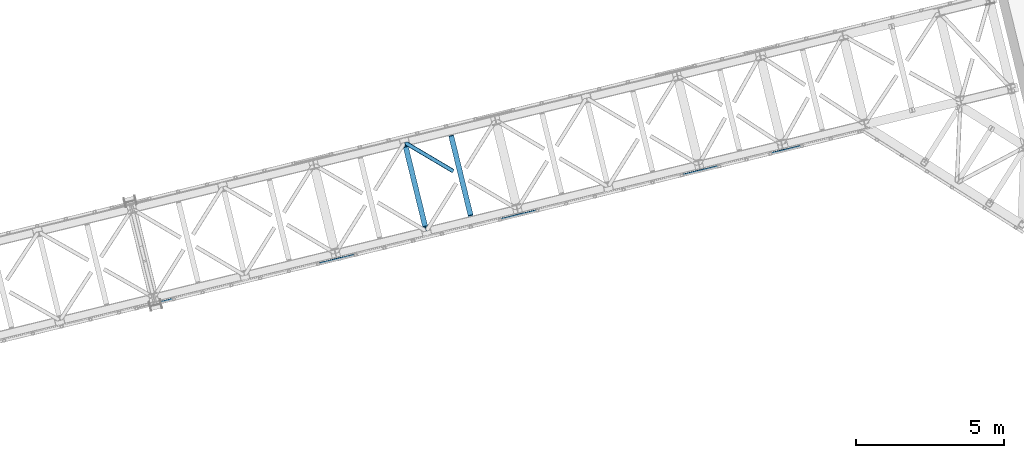
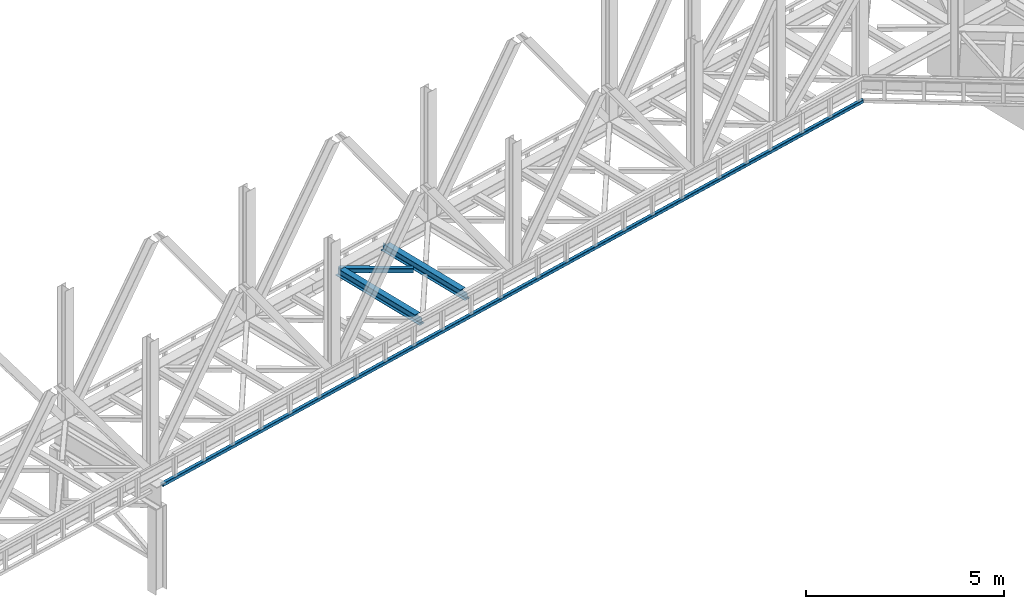
# One storey, part 66 of 92: 3 beams, 1 member.
"""IFC4 building model written with IfcOpenShell, lengths in millimetres."""

from ifc_helpers import new_model, entity, si_unit, converted_unit, derived_unit, direction, frame, origin, place, context, subcontext, project, spatial, triangles, polygons, material, type_object, element, save


model = new_model("IFC4")

# Units and contexts
model_context = context("Model", 3, precision=0.01, world=origin(), true_north=direction((6.12303176911189e-17, 1.0)))
plan_context = context("Plan", 3, precision=0.01, world=origin(), true_north=direction((6.12303176911189e-17, 1.0)))
body_context = subcontext(model_context, "Body", "Model", "MODEL_VIEW")
ifc_project = project(units=[si_unit("LENGTHUNIT", "METRE", prefix="MILLI"), si_unit("AREAUNIT", "SQUARE_METRE"), si_unit("VOLUMEUNIT", "CUBIC_METRE"), converted_unit("PLANEANGLEUNIT", "DEGREE", entity("IfcRatioMeasure", 0.0174532925199433), si_unit("PLANEANGLEUNIT", "RADIAN"), dimensions=[0, 0, 0, 0, 0, 0, 0]), si_unit("MASSUNIT", "GRAM", prefix="KILO"), derived_unit("MASSDENSITYUNIT", [(si_unit("MASSUNIT", "GRAM", prefix="KILO"), 1), (si_unit("LENGTHUNIT", "METRE"), -3)]), derived_unit("MOMENTOFINERTIAUNIT", [(si_unit("LENGTHUNIT", "METRE"), 4)]), si_unit("TIMEUNIT", "SECOND"), si_unit("FREQUENCYUNIT", "HERTZ"), si_unit("THERMODYNAMICTEMPERATUREUNIT", "DEGREE_CELSIUS"), derived_unit("THERMALTRANSMITTANCEUNIT", [(si_unit("MASSUNIT", "GRAM", prefix="KILO"), 1), (si_unit("THERMODYNAMICTEMPERATUREUNIT", "KELVIN"), -1), (si_unit("TIMEUNIT", "SECOND"), -3)]), derived_unit("VOLUMETRICFLOWRATEUNIT", [(si_unit("LENGTHUNIT", "METRE"), 3), (si_unit("TIMEUNIT", "SECOND"), -1)]), derived_unit("MASSFLOWRATEUNIT", [(si_unit("MASSUNIT", "GRAM", prefix="KILO"), 1), (si_unit("TIMEUNIT", "SECOND"), -1)]), derived_unit("ROTATIONALFREQUENCYUNIT", [(si_unit("TIMEUNIT", "SECOND"), -1)]), si_unit("ELECTRICCURRENTUNIT", "AMPERE"), si_unit("ELECTRICVOLTAGEUNIT", "VOLT"), si_unit("POWERUNIT", "WATT"), si_unit("FORCEUNIT", "NEWTON", prefix="KILO"), si_unit("ILLUMINANCEUNIT", "LUX"), si_unit("LUMINOUSFLUXUNIT", "LUMEN"), si_unit("LUMINOUSINTENSITYUNIT", "CANDELA"), derived_unit("USERDEFINED", [(si_unit("MASSUNIT", "GRAM", prefix="KILO"), -1), (si_unit("LENGTHUNIT", "METRE"), -2), (si_unit("TIMEUNIT", "SECOND"), 3), (si_unit("LUMINOUSFLUXUNIT", "LUMEN"), 1)]), derived_unit("LINEARVELOCITYUNIT", [(si_unit("LENGTHUNIT", "METRE"), 1), (si_unit("TIMEUNIT", "SECOND"), -1)]), si_unit("PRESSUREUNIT", "PASCAL"), derived_unit("USERDEFINED", [(si_unit("LENGTHUNIT", "METRE"), -2), (si_unit("MASSUNIT", "GRAM", prefix="KILO"), 1), (si_unit("TIMEUNIT", "SECOND"), -2)]), derived_unit("LINEARFORCEUNIT", [(si_unit("MASSUNIT", "GRAM", prefix="KILO"), 1), (si_unit("LENGTHUNIT", "METRE"), 1), (si_unit("TIMEUNIT", "SECOND"), -2), (si_unit("LENGTHUNIT", "METRE"), -1)]), derived_unit("PLANARFORCEUNIT", [(si_unit("MASSUNIT", "GRAM", prefix="KILO"), 1), (si_unit("LENGTHUNIT", "METRE"), 1), (si_unit("TIMEUNIT", "SECOND"), -2), (si_unit("LENGTHUNIT", "METRE"), -2)])], contexts=[model_context, plan_context])

# Site, building, storey
site_placement = place(None, origin())
site = spatial("IfcSite", under=ifc_project, at=site_placement, CompositionType="ELEMENT")
building_placement = place(site_placement, origin())
building = spatial("IfcBuilding", under=site, at=building_placement, CompositionType="ELEMENT")
storey_placement = place(building_placement, frame((0.0, 0.0, 15900.0)))
storey = spatial("IfcBuildingStorey", under=building, at=storey_placement, Name="05", CompositionType="ELEMENT", Elevation=15900.0)

# Beams
ifc_material = material(Name="Metal painted (White)")
beam_type_1 = type_object("IfcBeamType", PredefinedType="BEAM")
beam_1_placement = place(storey_placement, frame((-21033.99, 12667.67, 3441.0)))
element("IfcBeam", 1, at=beam_1_placement, inside=storey, type_object=beam_type_1, material=ifc_material, ObjectType="Steel Beam", PredefinedType="BEAM", context=body_context, shape_type="Tessellation", body=[
    polygons([(896.722476515612, 41.4445662733146, 11.000000000004), (896.722476515612, 41.4445662733146, 2.16573425859679e-12), (170.021610174765, 3022.65205668043, 2.16573425859679e-12), (170.021610174765, 3022.65205668043, 11.000000000004), (830.65693656199, 25.3403919499699, 11.000000000004), (103.956070221139, 3006.54788235708, 11.000000000004), (824.708186540694, 23.8903211957439, 12.2179274798217), (98.007320199847, 3005.09781160286, 12.2179274798217), (819.665079784585, 22.6610105689237, 15.6862915010257), (92.964213443734, 3003.86850097604, 15.6862915010257), (816.295383581409, 21.8396114687162, 20.8770650821657), (89.5945172405581, 3003.04710187583, 20.8770650821657), (815.112103631732, 21.5511744621271, 27.0000000000047), (88.4112372908809, 3002.75866486924, 27.0000000000047), (81.6103728838844, 3001.1008822183, 27.0000000000047), (81.6103728838888, 3001.1008822183, 203.000000000006), (88.4112372908939, 3002.75866486924, 203.000000000006), (0.0, 2981.20749040711, 2.16573425859679e-12), (4.33146851719357e-12, 2981.20749040712, 10.9999999999997), (66.0655399536302, 2997.31166473046, 11.000000000004), (72.0142899749184, 2998.76173548469, 12.2179274798195), (77.0573967310313, 2999.99104611151, 15.6862915010192), (80.4270929342072, 3000.81244521171, 20.8770650821657), (815.11210363174, 21.5511744621271, 203.000000000006), (808.311239224731, 19.8933918111941, 203.000000000006), (808.311239224731, 19.8933918111919, 27.0000000000047), (807.127959275054, 19.6049548046028, 20.8770650821657), (803.758263071878, 18.7835557043952, 15.6862915010192), (798.715156315769, 17.5542450775729, 12.2179274798195), (792.766406294477, 16.1041743233468, 11.000000000004), (726.700866340851, 2.16573425859679e-12, 10.9999999999997), (726.700866340847, 2.16573425859679e-12, 2.16573425859679e-12), (775.945201911975, 182.229070489536, 203.069792164282), (124.290390378924, 2855.56852806081, 203.000000000006), (124.513271168078, 2854.65418562638, 203.617301946336), (124.526185412598, 2854.60120565349, 217.000003693143), (775.799998669244, 182.824605273263, 217.000003676718), (775.800869277142, 182.821033832383, 204.00000679514), (769.234900758903, 180.199471824636, 203.006342981088), (769.012053092176, 181.113823838963, 203.617301946336), (768.999138847657, 181.166803811856, 217.000003693143), (117.725325591011, 2852.94340419209, 217.000003676718), (117.724454983117, 2852.94697563296, 204.00000679514), (117.580155394058, 2853.53894853354, 203.076120467494), (117.489525971923, 2853.91074540987, 203.000000000006), (776.983483393267, 183.112202246701, 223.122939328039), (780.352479801942, 183.936472070578, 228.313710402595), (785.395115205966, 185.167716295886, 231.782072735464), (791.343694076674, 186.618489150568, 232.999999602236), (857.409144942201, 202.723028934504, 232.999999283132), (857.407671605764, 202.729072911377, 243.999994005812), (687.386290701834, 161.283566114484, 243.999994827032), (687.387764038276, 161.277522137611, 233.000000104353), (753.453214903804, 177.382061921547, 232.999999785253), (759.402120032129, 178.83149638977, 231.782072861016), (764.445684539269, 180.058929212905, 228.313710479427), (767.816071449005, 180.877494870334, 223.12293937232), (116.541840866984, 2852.65580721864, 223.122939328039), (113.172844458304, 2851.83153739476, 228.313710402595), (108.130209054276, 2850.60029316945, 231.782072735464), (102.181630183577, 2849.14952031477, 232.999999602236), (36.1161793180448, 2833.04498053084, 232.999999283128), (36.1176526544823, 2833.03893655396, 243.999994005812), (206.139033558408, 2874.48444335086, 243.999994827032), (206.13756022197, 2874.49048732773, 233.000000104357), (140.072109356447, 2858.38594754379, 232.999999785253), (134.123204228112, 2856.93651307557, 231.782072861012), (129.079639720982, 2855.70908025244, 228.313710479427), (125.709252811241, 2854.89051459501, 223.12293937232)], [[[1, 2, 3, 4]], [[5, 1, 4, 6]], [[7, 5, 6, 8]], [[9, 7, 8, 10]], [[11, 9, 10, 12]], [[13, 11, 12, 14]], [[15, 16, 17, 14, 12, 10, 8, 6, 4, 3, 18, 19, 20, 21, 22, 23]], [[13, 24, 25, 26, 27, 28, 29, 30, 31, 32, 2, 1, 5, 7, 9, 11]], [[2, 32, 18, 3]], [[32, 31, 19, 18]], [[31, 30, 20, 19]], [[27, 26, 15, 23]], [[28, 27, 23, 22]], [[29, 28, 22, 21]], [[30, 29, 21, 20]], [[33, 24, 13, 14, 17, 34, 35, 36, 37, 38]], [[25, 39, 40, 41, 42, 43, 44, 16, 15, 26]], [[39, 25, 24, 33]], [[45, 34, 17, 16]], [[41, 40, 38, 37, 46, 47, 48, 49, 50, 51, 52, 53, 54, 55, 56, 57]], [[42, 58, 59, 60, 61, 62, 63, 64, 65, 66, 67, 68, 69, 36, 35, 43]], [[46, 37, 36, 69]], [[47, 46, 69, 68]], [[48, 47, 68, 67]], [[49, 48, 67, 66]], [[50, 49, 66, 65]], [[51, 50, 65, 64]], [[52, 51, 64, 63]], [[53, 52, 63, 62]], [[54, 53, 62, 61]], [[55, 54, 61, 60]], [[56, 55, 60, 59]], [[57, 56, 59, 58]], [[41, 57, 58, 42]]], closed=False),
])
beam_2_placement = place(storey_placement, frame((-19498.94, 13041.86, 3441.0)))
element("IfcBeam", 2, at=beam_2_placement, inside=storey, type_object=beam_type_1, material=ifc_material, ObjectType="Steel Beam", PredefinedType="BEAM", context=body_context, shape_type="Tessellation", body=[
    polygons([(896.722476515612, 41.4445662733125, 11.000000000004), (896.722476515612, 41.4445662733125, 2.16573425859679e-12), (170.021610174761, 3022.65205668042, 2.16573425859679e-12), (170.021610174763, 3022.65205668042, 11.000000000004), (830.656936561993, 25.3403919499656, 11.000000000004), (103.956070221144, 3006.54788235708, 11.000000000004), (824.708186540689, 23.8903211957374, 12.217927479826), (98.0073201998383, 3005.09781160285, 12.217927479826), (819.665079784589, 22.6610105689237, 15.6862915010192), (92.9642134437362, 3003.86850097603, 15.6862915010192), (816.295383581413, 21.8396114687119, 20.8770650821657), (89.5945172405603, 3003.04710187582, 20.8770650821657), (815.11210363173, 21.5511744621227, 27.0000000000047), (88.4112372908809, 3002.75866486924, 27.0000000000047), (81.6103728838822, 3001.1008822183, 27.0000000000047), (81.6103728838801, 3001.1008822183, 203.000000000006), (88.4112372908809, 3002.75866486924, 203.000000000006), (0.0, 2981.20749040711, 2.16573425859679e-12), (2.16573425859679e-12, 2981.20749040711, 10.9999999999997), (66.0655399536216, 2997.31166473045, 11.000000000004), (72.0142899749205, 2998.76173548469, 12.2179274798217), (77.0573967310183, 2999.9910461115, 15.686291501017), (80.4270929342029, 3000.81244521171, 20.8770650821657), (815.112103631732, 21.5511744621249, 203.000000000006), (808.311239224731, 19.8933918111897, 203.000000000006), (808.311239224731, 19.8933918111897, 27.0000000000047), (807.127959275052, 19.6049548045984, 20.8770650821657), (803.758263071869, 18.7835557043909, 15.686291501017), (798.715156315769, 17.5542450775729, 12.2179274798217), (792.766406294472, 16.1041743233447, 11.000000000004), (726.700866340851, 2.16573425859679e-12, 10.9999999999997), (726.700866340851, 2.16573425859679e-12, 2.16573425859679e-12), (775.945201911964, 182.229070489534, 203.069792164282), (124.290390378922, 2855.5685280608, 203.000000000006), (124.513271168068, 2854.65418562638, 203.617301946336), (124.526185412589, 2854.60120565348, 217.000003693143), (775.79999866924, 182.824605273258, 217.000003676718), (775.800869277134, 182.821033832379, 204.00000679514), (769.234900758899, 180.199471824632, 203.006342981088), (769.012053092174, 181.113823838958, 203.617301946336), (768.999138847649, 181.166803811849, 217.000003693143), (117.725325591002, 2852.94340419208, 217.000003676718), (117.724454983108, 2852.94697563296, 204.00000679514), (117.580155394052, 2853.53894853353, 203.076120467494), (117.489525971919, 2853.91074540987, 203.000000000006), (776.983483393269, 183.112202246699, 223.122939328039), (780.352479801942, 183.93647207058, 228.313710402595), (785.395115205957, 185.167716295882, 231.78207273546), (791.343694076674, 186.618489150565, 232.999999602236), (857.40914494219, 202.723028934499, 232.999999283132), (857.407671605755, 202.729072911373, 243.999994005812), (687.38629070184, 161.283566114482, 243.999994827032), (687.38776403828, 161.277522137609, 233.000000104353), (753.453214903799, 177.382061921543, 232.999999785253), (759.402120032134, 178.831496389768, 231.782072861012), (764.445684539254, 180.058929212901, 228.313710479431), (767.816071449001, 180.877494870332, 223.12293937232), (116.541840866979, 2852.65580721863, 223.122939328039), (113.172844458293, 2851.83153739476, 228.313710402599), (108.130209054278, 2850.60029316945, 231.782072735464), (102.181630183568, 2849.14952031477, 232.999999602236), (36.1161793180448, 2833.04498053084, 232.999999283128), (36.1176526544823, 2833.03893655396, 243.999994005812), (206.139033558399, 2874.48444335085, 243.999994827032), (206.137560221957, 2874.49048732772, 233.000000104357), (140.072109356447, 2858.38594754379, 232.999999785253), (134.123204228102, 2856.93651307557, 231.782072861007), (129.079639720982, 2855.70908025243, 228.313710479427), (125.709252811245, 2854.89051459501, 223.12293937232)], [[[1, 2, 3, 4]], [[5, 1, 4, 6]], [[7, 5, 6, 8]], [[9, 7, 8, 10]], [[11, 9, 10, 12]], [[13, 11, 12, 14]], [[15, 16, 17, 14, 12, 10, 8, 6, 4, 3, 18, 19, 20, 21, 22, 23]], [[13, 24, 25, 26, 27, 28, 29, 30, 31, 32, 2, 1, 5, 7, 9, 11]], [[2, 32, 18, 3]], [[32, 31, 19, 18]], [[31, 30, 20, 19]], [[27, 26, 15, 23]], [[28, 27, 23, 22]], [[29, 28, 22, 21]], [[30, 29, 21, 20]], [[33, 24, 13, 14, 17, 34, 35, 36, 37, 38]], [[25, 39, 40, 41, 42, 43, 44, 16, 15, 26]], [[39, 25, 24, 33]], [[45, 34, 17, 16]], [[41, 40, 38, 37, 46, 47, 48, 49, 50, 51, 52, 53, 54, 55, 56, 57]], [[42, 58, 59, 60, 61, 62, 63, 64, 65, 66, 67, 68, 69, 36, 35, 43]], [[46, 37, 36, 69]], [[47, 46, 69, 68]], [[48, 47, 68, 67]], [[49, 48, 67, 66]], [[50, 49, 66, 65]], [[51, 50, 65, 64]], [[52, 51, 64, 63]], [[53, 52, 63, 62]], [[54, 53, 62, 61]], [[55, 54, 61, 60]], [[56, 55, 60, 59]], [[57, 56, 59, 58]], [[41, 57, 58, 42]]], closed=False),
])

# Member
member_type = type_object("IfcMemberType", PredefinedType="BRACE")
member_placement = place(storey_placement, frame((-20945.29, 14645.78, 3510.0)))
element("IfcMember", 3, at=member_placement, inside=storey, type_object=member_type, ObjectType="Steel Horizontal Brace", PredefinedType="BRACE", context=body_context, shape_type="Tessellation", body=[
    triangles([(1672.21653442383, 120.471716308593, 122.500662231447), (1672.21653442383, 120.471716308593, 17.5000946044929), (91.5013916015632, 1056.29133911133, 122.500662231447), (91.5013916015632, 1056.29133911133, 17.5000946044929), (1663.30196228027, 105.413333129884, 139.999594116212), (1666.71221923828, 111.175772094726, 138.667117309571), (76.4813781738267, 1052.62993469238, 138.667117309571), (67.167993164061, 1050.36030578613, 139.999594116212), (1669.60506591797, 116.060357666016, 134.874325561526), (84.376245117186, 1054.55423583984, 134.874325561526), (1671.53750610352, 119.325274658204, 129.197927856447), (89.6480163574233, 1055.84020385742, 129.197927856447), (18.7686218261733, 956.992749023439, 139.999594116212), (1609.80987854004, 15.0595458984371, 139.999594116212), (0.0, 1033.98688659668, 139.999594116212), (1600.89065551758, 0.0, 122.500662231447), (1601.57317199707, 1.14760437011682, 129.197927856447), (24.5612915039055, 933.226757812501, 122.500662231447), (24.1217834472664, 935.035949707031, 129.197927856447), (1603.50677490234, 4.41135864257922, 134.874325561526), (22.8660461425789, 940.18796081543, 134.874325561526), (1606.39962158203, 9.29710693359448, 138.667117309571), (20.9847656249985, 947.897955322265, 138.667117309571), (1600.89065551758, 0.0, 17.5000946044929), (24.5612915039055, 933.226757812501, 17.5000946044929), (1671.53750610352, 119.325274658204, 10.8028289794929), (89.5619750976548, 1055.81927490234, 10.8167816162131), (162.736578369142, 1012.4207611084, 10.5005218505867), (1669.60506591797, 116.060357666016, 5.12526855468968), (165.152709960938, 1006.73157348633, 5.12526855468968), (164.09696044922, 1011.0638671875, 9.50058288574292), (163.769073486328, 1011.39059143067, 9.74126586914281), (163.420257568359, 1011.74289550781, 10.0005523681648), (163.066790771485, 1012.09287414551, 10.2586761474631), (89.473608398439, 1055.79718322754, 10.5005218505867), (1666.71221923828, 111.175772094726, 1.33247680664135), (167.033990478514, 999.020416259766, 1.33247680664135), (1663.30196228027, 105.413333129884, 0.0), (169.250134277343, 989.925622558594, 0.0), (1609.80987854004, 15.0595458984371, 0.0), (204.010803222656, 847.325024414064, 0.0), (166.88748779297, 995.391567993165, 10.5005218505867), (72.0351379394524, 1051.54627990723, 10.5005218505867), (168.582733154297, 992.660339355469, 9.50058288574292), (168.166479492189, 993.33355407715, 9.74591674804833), (167.738598632812, 994.02653503418, 10.0005523681648), (167.306066894533, 994.718353271484, 10.2540252685576), (1666.03784179688, 110.037469482422, 12.1260040283232), (1667.97028198242, 113.301223754883, 17.8035644531265), (79.9160522460952, 1053.46709289551, 17.8035644531265), (1663.14499511719, 105.151721191407, 8.3320495605476), (169.398962402345, 989.317520141602, 8.81690368652562), (74.1140808105483, 1052.05322570801, 12.4271484375022), (171.566271972657, 980.419226074218, 6.99957275390625), (1659.73357543945, 99.3892822265625, 6.99957275390625), (1668.64814758301, 114.447665405274, 24.4996673583992), (81.7694274902351, 1053.91822814941, 24.4996673583992), (1668.64814758301, 114.447665405274, 115.501089477541), (81.7694274902351, 1053.91822814941, 115.501089477541), (74.641955566407, 1052.18228759766, 127.87475280762), (66.7494140624985, 1050.25798645019, 131.667544555665), (79.9160522460952, 1053.46709289551, 122.196029663086), (57.4360290527329, 1047.98719482422, 133.000021362306), (0.0, 1033.98688659668, 133.000021362306), (1667.97028198242, 113.301223754883, 122.196029663086), (1666.03784179688, 110.037469482422, 127.87475280762), (1663.14499511719, 105.151721191407, 131.667544555665), (1659.73357543945, 99.3892822265625, 133.000021362306), (16.4501586914048, 966.50030822754, 133.000021362306), (1613.37361450195, 21.0824340820309, 133.000021362306), (1613.37361450195, 21.0824340820309, 6.99957275390625), (201.692340087891, 856.832583618165, 6.99957275390625), (1607.06934814453, 10.434246826173, 127.87475280762), (1609.96219482422, 15.3199951171882, 131.667544555665), (1604.4590423584, 6.02405090332104, 115.501089477541), (1605.13690795899, 7.17049255371057, 122.196029663086), (1606.39962158203, 9.29710693359448, 1.33247680664135), (1607.06934814453, 10.434246826173, 12.1260040283232), (1603.50677490234, 4.41135864257922, 5.12526855468968), (1609.96219482422, 15.3199951171882, 8.3320495605476), (1601.57317199707, 1.14760437011682, 10.8028289794929), (1604.4590423584, 6.02405090332104, 24.4996673583992), (1605.13690795899, 7.17049255371057, 17.8035644531265), (18.6686279296882, 957.404351806641, 131.667544555665), (20.547583007814, 949.694357299804, 127.87475280762), (21.8033203125015, 944.542346191407, 122.196029663086), (22.2451538085952, 942.733154296875, 115.501089477541), (22.2451538085952, 942.733154296875, 24.4996673583992), (21.7823913574211, 944.627224731446, 17.8163543701194), (21.7614624023445, 944.717916870117, 17.5000946044929), (203.861975097658, 847.933126831054, 8.81690368652562), (206.226947021485, 838.23023071289, 1.33247680664135), (204.678204345702, 844.590307617187, 9.50058288574292), (208.105902099611, 830.520236206055, 5.12526855468968), (209.163977050783, 826.187942504883, 9.50058288574292), (204.682855224608, 843.327593994141, 10.2075164794951), (204.324737548828, 843.305502319336, 10.3540191650391), (203.966619873048, 843.284573364259, 10.5005218505867), (27.0146301269524, 945.867846679688, 12.1260040283232), (28.3471069335938, 947.254971313478, 10.5005218505867), (204.682855224608, 843.958950805665, 9.85404968261719), (32.1398986816421, 930.362979125977, 10.8179443359404), (209.136071777342, 825.983303833009, 9.88311767578125), (208.117529296876, 826.255380249024, 10.5005218505867), (208.803533935548, 826.071670532227, 10.0842681884787), (32.4980163574219, 930.225778198243, 10.5005218505867)], [[1, 2, 3], [4, 3, 2], [5, 6, 7], [7, 8, 5], [6, 9, 10], [10, 7, 6], [9, 11, 12], [12, 10, 9], [11, 1, 3], [3, 12, 11], [5, 13, 14], [13, 5, 8], [15, 13, 8], [16, 17, 18], [19, 18, 17], [17, 20, 19], [21, 19, 20], [20, 22, 21], [23, 21, 22], [22, 14, 23], [13, 23, 14], [24, 16, 18], [18, 25, 24], [26, 27, 4], [27, 26, 28], [26, 29, 30], [30, 31, 26], [26, 32, 33], [32, 26, 31], [26, 34, 28], [34, 26, 33], [28, 35, 27], [29, 36, 37], [37, 30, 29], [36, 38, 39], [39, 37, 36], [4, 2, 26], [38, 40, 41], [41, 39, 38], [28, 42, 35], [43, 35, 42], [31, 44, 45], [45, 32, 31], [32, 45, 46], [46, 33, 32], [33, 46, 47], [47, 34, 33], [34, 47, 42], [42, 28, 34], [48, 49, 50], [45, 51, 46], [45, 44, 51], [42, 47, 51], [47, 46, 51], [44, 52, 51], [48, 53, 42], [42, 51, 48], [53, 43, 42], [51, 52, 54], [54, 55, 51], [50, 53, 48], [49, 56, 57], [57, 50, 49], [56, 58, 59], [59, 57, 56], [60, 61, 7], [10, 60, 7], [10, 12, 62], [60, 10, 62], [62, 12, 3], [61, 8, 7], [15, 63, 64], [15, 8, 63], [61, 63, 8], [62, 3, 59], [57, 4, 50], [3, 57, 59], [4, 27, 50], [3, 4, 57], [35, 50, 27], [35, 53, 50], [35, 43, 53], [58, 65, 59], [62, 59, 65], [65, 66, 62], [60, 62, 66], [66, 67, 60], [61, 60, 67], [67, 68, 61], [63, 61, 68], [68, 69, 63], [68, 70, 69], [69, 64, 63], [71, 55, 72], [54, 72, 55], [11, 66, 65], [58, 2, 1], [11, 65, 1], [11, 9, 66], [65, 58, 1], [66, 9, 6], [68, 5, 14], [5, 67, 6], [67, 5, 68], [67, 66, 6], [26, 48, 29], [56, 2, 58], [2, 49, 26], [49, 2, 56], [26, 49, 48], [38, 55, 40], [36, 29, 48], [48, 51, 36], [51, 55, 38], [38, 36, 51], [73, 22, 20], [14, 70, 68], [14, 74, 70], [74, 14, 22], [73, 74, 22], [75, 16, 24], [17, 76, 73], [20, 17, 73], [76, 17, 16], [75, 76, 16], [77, 78, 79], [40, 55, 71], [71, 80, 40], [80, 78, 77], [77, 40, 80], [81, 79, 78], [24, 82, 75], [83, 24, 81], [24, 83, 82], [83, 81, 78], [70, 74, 84], [84, 69, 70], [74, 73, 85], [85, 84, 74], [73, 76, 86], [86, 85, 73], [76, 75, 87], [87, 86, 76], [75, 82, 87], [88, 87, 82], [86, 87, 18], [18, 19, 86], [21, 86, 19], [86, 21, 85], [18, 88, 25], [89, 90, 25], [25, 88, 89], [87, 88, 18], [84, 23, 13], [15, 69, 13], [64, 69, 15], [84, 85, 23], [23, 85, 21], [69, 84, 13], [44, 30, 37], [39, 44, 37], [54, 52, 39], [54, 39, 72], [30, 44, 31], [39, 52, 44], [72, 41, 91], [41, 92, 93], [41, 72, 39], [94, 93, 92], [41, 93, 91], [94, 95, 93], [83, 89, 88], [71, 72, 91], [78, 96, 97], [97, 98, 78], [98, 99, 78], [98, 100, 99], [80, 91, 93], [93, 78, 80], [78, 93, 101], [101, 96, 78], [83, 78, 99], [99, 90, 83], [90, 89, 83], [91, 80, 71], [88, 82, 83], [24, 25, 102], [79, 103, 95], [81, 102, 104], [104, 79, 81], [104, 105, 79], [95, 94, 79], [40, 77, 92], [92, 41, 40], [77, 79, 94], [94, 92, 77], [106, 81, 24], [99, 106, 25], [99, 100, 106], [25, 90, 99], [98, 104, 106], [106, 100, 98]]),
])

# Beam
beam_type_2 = type_object("IfcBeamType", PredefinedType="BEAM")
beam_3_placement = place(storey_placement, frame((-29196.9, 10223.71, 3068.0)))
element("IfcBeam", 4, at=beam_3_placement, inside=storey, type_object=beam_type_2, ObjectType="Steel Beam", PredefinedType="BEAM", context=body_context, shape_type="Tessellation", body=[
    triangles([(23740.1770889282, 5873.7821685791, 0.0), (23726.1331787109, 5788.01531066895, 0.0), (2.36729736328198, 87.4400115966801, 0.0), (21.3149780273452, 9.71568603515698, 0.0), (0.0, 97.1545349121097, 9.9993896484375), (23741.9339584351, 5884.50244445801, 9.9993896484375), (23741.6758346558, 5882.93277282715, 6.4647216796875), (0.181384277344478, 96.4150451660153, 6.17287902831958), (23741.4211990356, 5881.36310119629, 2.92889099121021), (0.692980957031978, 94.3093597412117, 2.92889099121021), (23740.7991439819, 5877.5726348877, 1.46386413574146), (1.46270141601417, 91.1572265625, 0.760418701171147), (0.0, 97.1545349121097, 90.0003204345703), (23741.9339584351, 5884.50244445801, 90.0003204345703), (1.46270141601417, 91.1572265625, 99.2381286621094), (2.36729736328198, 87.4400115966801, 99.9997100830078), (23740.1770889282, 5873.7821685791, 99.9997100830078), (0.692980957031978, 94.3093597412117, 97.0708190917976), (23740.7991439819, 5877.5726348877, 98.5358459472664), (0.181384277344478, 96.4150451660153, 93.8268310546882), (23741.4211990356, 5881.36310119629, 97.0708190917976), (23741.6758346558, 5882.93277282715, 93.5349884033203), (23726.1331787109, 5788.01531066895, 99.9997100830078), (21.3149780273452, 9.71568603515698, 99.9997100830078), (23.5032165527336, 0.739489746094478, 93.8268310546882), (23.6822753906235, 0.0, 90.0003204345703), (23724.3757278442, 5777.29503479004, 90.0003204345703), (22.9892944335952, 2.84517517089807, 97.0708190917976), (23724.6344329834, 5778.8647064209, 93.5349884033203), (22.2195739746094, 5.99730834960974, 99.2381286621094), (23724.8931381226, 5780.43554077148, 97.0708190917976), (23725.5111236572, 5784.22484436035, 98.5358459472664), (23.6822753906235, 0.0, 9.9993896484375), (23724.3757278442, 5777.29503479004, 9.9993896484375), (23725.5111236572, 5784.22484436035, 1.46386413574146), (22.2195739746094, 5.99730834960974, 0.760418701171147), (23724.8931381226, 5780.43554077148, 2.92889099121021), (22.9892944335952, 2.84517517089807, 2.92889099121021), (23724.6344329834, 5778.8647064209, 6.4647216796875), (23.5032165527336, 0.739489746094478, 6.17287902831958), (1.87662963867115, 89.4515167236332, 7.92858581542896), (1.36503295898365, 91.5583648681641, 11.1725738525383), (1.18364868163917, 92.2978546142585, 15.0002471923835), (3.55327148437573, 82.5821685791016, 4.99969482421875), (2.64635009765698, 86.2993835449215, 5.76127624511719), (1.87662963867115, 89.4515167236332, 92.0711242675789), (1.18364868163917, 92.2978546142585, 84.9994628906243), (1.36503295898365, 91.5583648681641, 88.8271362304695), (3.55327148437573, 82.5821685791016, 95.0000152587891), (2.64635009765698, 86.2993835449215, 94.2384338378906), (21.8056457519524, 7.70301818847656, 7.92858581542896), (20.1313293457024, 14.5735290527355, 4.99969482421875), (21.0359252929702, 10.8551513671882, 5.76127624511719), (22.4986267089844, 4.85784301757849, 15.0002471923835), (22.3172424316399, 5.59733276367297, 11.1725738525383), (21.8056457519524, 7.70301818847656, 92.0711242675789), (20.1313293457024, 14.5735290527355, 95.0000152587891), (21.0359252929702, 10.8551513671882, 94.2384338378906), (22.4986267089844, 4.85784301757849, 84.9994628906243), (22.3172424316399, 5.59733276367297, 88.8271362304695), (23740.5404388428, 5876.00180053711, 7.92858581542896), (23739.923034668, 5872.21249694824, 6.4647216796875), (23740.5404388428, 5876.00180053711, 92.0711242675789), (23740.7991439819, 5877.5726348877, 88.5352935791016), (23741.0578491211, 5879.14230651856, 84.9994628906243), (23741.0578491211, 5879.14230651856, 15.0002471923835), (23739.3009796143, 5868.42203063965, 95.0000152587891), (23727.0092880249, 5793.3754486084, 95.0000152587891), (23739.923034668, 5872.21249694824, 93.5349884033203), (23740.7991439819, 5877.5726348877, 11.4644165039063), (23739.3009796143, 5868.42203063965, 4.99969482421875), (23725.7692474365, 5785.79567871094, 92.0711242675789), (23725.5111236572, 5784.22484436035, 88.5352935791016), (23726.3918838501, 5789.58614501953, 93.5349884033203), (23725.2564880371, 5782.65517272949, 84.9994628906243), (23725.7692474365, 5785.79567871094, 7.92858581542896), (23727.0092880249, 5793.3754486084, 4.99969482421875), (23726.3918838501, 5789.58614501953, 6.4647216796875), (23725.2564880371, 5782.65517272949, 15.0002471923835), (23725.5111236572, 5784.22484436035, 11.4644165039063)], [[1, 2, 3], [4, 3, 2], [5, 6, 7], [8, 7, 9], [10, 9, 11], [12, 11, 1], [1, 3, 12], [11, 12, 10], [9, 10, 8], [7, 8, 5], [6, 5, 13], [13, 14, 6], [15, 16, 17], [18, 15, 19], [20, 18, 21], [13, 20, 22], [22, 14, 13], [21, 22, 20], [19, 21, 18], [17, 19, 15], [23, 17, 16], [16, 24, 23], [25, 26, 27], [28, 25, 29], [30, 28, 31], [24, 30, 32], [32, 23, 24], [31, 32, 30], [29, 31, 28], [27, 29, 25], [33, 34, 27], [27, 26, 33], [4, 2, 35], [36, 35, 37], [38, 37, 39], [40, 39, 34], [34, 33, 40], [39, 40, 38], [37, 38, 36], [35, 36, 4], [8, 41, 42], [43, 13, 5], [8, 42, 5], [8, 10, 41], [42, 43, 5], [41, 10, 12], [44, 3, 4], [3, 45, 12], [45, 3, 44], [45, 41, 12], [20, 46, 18], [47, 13, 43], [13, 48, 20], [48, 13, 47], [20, 48, 46], [16, 49, 24], [15, 18, 46], [46, 50, 15], [50, 49, 16], [16, 15, 50], [51, 36, 38], [4, 52, 44], [4, 53, 52], [53, 4, 36], [51, 53, 36], [54, 33, 26], [40, 55, 51], [38, 40, 51], [55, 40, 33], [54, 55, 33], [30, 56, 28], [24, 49, 57], [57, 58, 24], [58, 56, 30], [30, 24, 58], [25, 28, 56], [26, 59, 54], [60, 26, 25], [26, 60, 59], [60, 25, 56], [9, 61, 62], [22, 63, 64], [65, 66, 14], [14, 22, 64], [21, 63, 22], [64, 65, 14], [63, 21, 19], [67, 17, 68], [17, 69, 19], [69, 17, 67], [69, 63, 19], [66, 6, 14], [70, 7, 6], [70, 6, 66], [11, 62, 1], [7, 70, 61], [9, 62, 11], [1, 71, 2], [71, 1, 62], [72, 29, 73], [23, 68, 17], [23, 32, 74], [23, 74, 68], [74, 32, 72], [73, 27, 75], [29, 72, 31], [31, 72, 32], [75, 27, 34], [29, 27, 73], [35, 76, 37], [2, 71, 77], [78, 2, 77], [35, 78, 76], [35, 2, 78], [39, 37, 76], [34, 79, 75], [80, 34, 39], [34, 80, 79], [80, 39, 76], [61, 9, 7], [77, 71, 44], [44, 52, 77], [45, 44, 71], [41, 45, 62], [42, 41, 61], [43, 42, 70], [70, 66, 43], [61, 70, 42], [62, 61, 41], [71, 62, 45], [43, 66, 65], [65, 47, 43], [47, 65, 64], [48, 64, 63], [46, 63, 69], [50, 69, 67], [67, 49, 50], [69, 50, 46], [63, 46, 48], [64, 48, 47], [67, 68, 49], [57, 49, 68], [57, 68, 74], [58, 74, 72], [56, 72, 73], [60, 73, 75], [75, 59, 60], [73, 60, 56], [72, 56, 58], [74, 58, 57], [79, 54, 75], [59, 75, 54], [55, 54, 79], [51, 55, 80], [53, 51, 76], [52, 53, 78], [78, 77, 52], [76, 78, 53], [80, 76, 51], [79, 80, 55]]),
])

save(model, "model.ifc")
